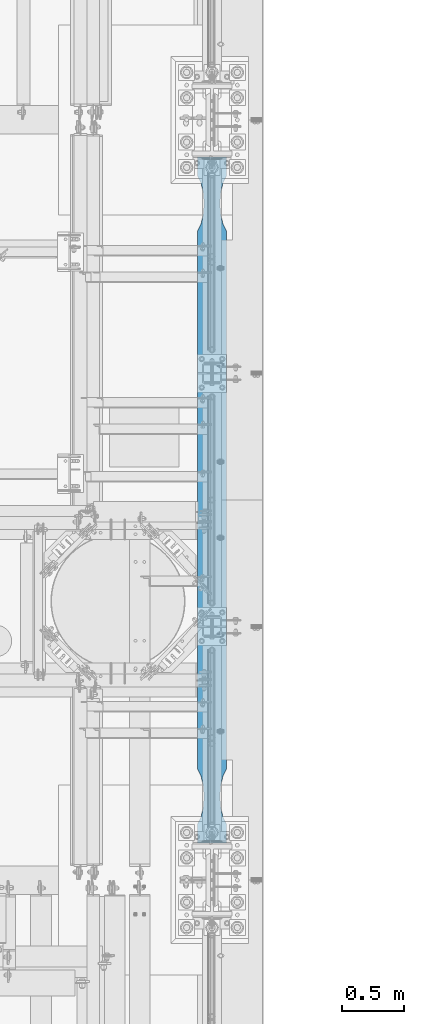
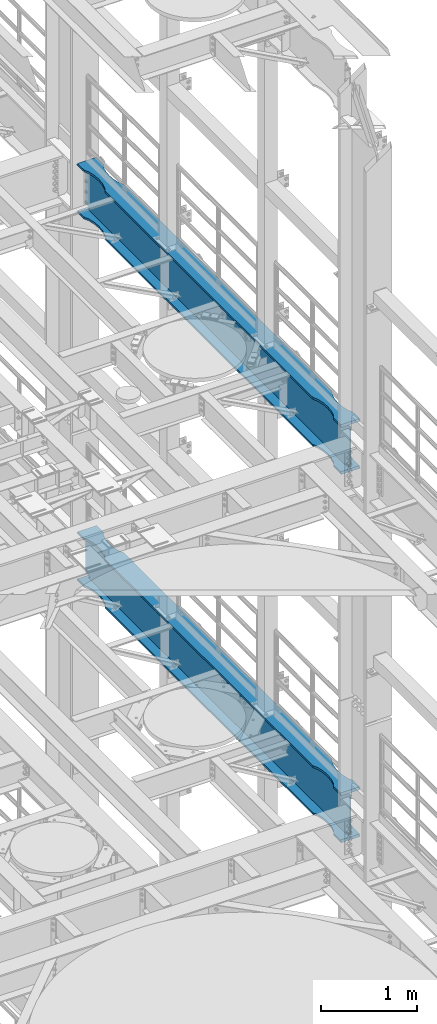
# One storey, part 1038 of 1876: 2 beams, 2 elements without a shape of their own.
"""IFC2X3 building model written with IfcOpenShell, lengths in millimetres."""

from ifc_helpers import new_model, si_unit, frame, origin_with_axes, place, context, subcontext, project, spatial, faceted_brep, material, type_object, element, aggregate, save


model = new_model("IFC2X3")

# Units and contexts
model_context = context("Model", 3, precision=1e-05, world=origin_with_axes())
body_context = subcontext(model_context, "Body", "Model", "MODEL_VIEW")
ifc_project = project(units=[si_unit("LENGTHUNIT", "METRE", prefix="MILLI"), si_unit("AREAUNIT", "SQUARE_METRE"), si_unit("VOLUMEUNIT", "CUBIC_METRE"), si_unit("MASSUNIT", "GRAM", prefix="KILO"), si_unit("TIMEUNIT", "SECOND"), si_unit("PLANEANGLEUNIT", "RADIAN"), si_unit("SOLIDANGLEUNIT", "STERADIAN"), si_unit("THERMODYNAMICTEMPERATUREUNIT", "DEGREE_CELSIUS"), si_unit("LUMINOUSINTENSITYUNIT", "LUMEN")], contexts=[model_context])

# Site, building, storey
site_placement = place(None, origin_with_axes())
site = spatial("IfcSite", under=ifc_project, at=site_placement, CompositionType="ELEMENT")
building_placement = place(site_placement, origin_with_axes())
building = spatial("IfcBuilding", under=site, at=building_placement, Name="Undefined", CompositionType="ELEMENT")
storey_placement = place(building_placement, origin_with_axes())
storey = spatial("IfcBuildingStorey", under=building, at=storey_placement, Name="Undefined", CompositionType="ELEMENT", Elevation=0.0)

# Assembly, beam
assembly_1_placement = place(storey_placement, origin_with_axes())
assembly_1 = element("IfcElementAssembly", 1, at=assembly_1_placement, inside=storey, Name="BEAM", AssemblyPlace="NOTDEFINED", PredefinedType="RIGID_FRAME")
ifc_material = material(Name="STEEL/A992")
beam_type = type_object("IfcBeamType", Name="W24X103", PredefinedType="NOTDEFINED")
beam_1_placement = place(assembly_1_placement, frame((7620.0, 1524.0, 17672.05), z_axis=(0.0, 0.0, 1.0), x_axis=(0.0, 1.0, 0.0)))
beam_1 = element("IfcBeam", 2, at=beam_1_placement, type_object=beam_type, material=ifc_material, Name="BEAM", ObjectType="W24X103", context=body_context, shape_type="Brep", body=[
    faceted_brep([(5789.6125, -7.14375000000018, -250.825000000001), (5797.55, 7.14375000000018, -250.825000000001), (5797.55, 7.14375000000018, 250.825000000001), (5789.6125, -7.14375000000018, 250.825000000001), (306.3875, -7.14375000000018, 250.825000000001), (298.45, 7.14375000000018, 250.825000000001), (298.45, 7.14375000000018, -250.825000000001), (306.3875, -7.14375000000018, -250.825000000001), (5641.97500876196, 114.299992330618, -285.75), (5641.97500876196, 114.3, -311.150000000001), (5592.87586146151, 88.8999957361821, -311.150000000001), (5592.87586146151, 88.8999957361821, -285.75), (5510.43685211057, 69.8863924058523, -311.150000000001), (5510.43685211057, 69.8863924058523, -285.75), (5426.0750039875, 63.5000040971918, -311.150000000001), (5426.0750039875, 63.5000040971918, -285.75), (5341.71315599965, 69.8863941921136, -311.150000000001), (5341.71315599965, 69.8863941921136, -285.75), (5259.2741470513, 88.8999992679901, -311.150000000001), (5259.2741470513, 88.8999992679901, -285.75), (5210.175, 114.3, -311.150000000001), (5210.175, 114.3, -285.75), (885.825008761703, 114.3, -311.150000000001), (885.825008761703, 114.299990374483, -285.75), (836.72586171043, 88.899989642473, -311.150000000001), (836.72586171043, 88.899989642473, -285.75), (754.286852762112, 69.8863845665965, -311.150000000001), (754.286852762112, 69.8863845665965, -285.75), (669.925004774302, 63.4999944716747, -311.150000000001), (669.925004774302, 63.4999944716747, -285.75), (585.563156651265, 69.8863827803352, -311.150000000001), (585.563156651265, 69.8863827803352, -285.75), (503.124147300347, 88.8999861106649, -311.150000000001), (503.124147300347, 88.8999861106649, -285.75), (454.024999999921, 114.3, -311.150000000001), (454.024999999921, 114.3, -285.75), (298.45, 114.3, -311.150000000001), (313.11459905754, 114.3, -285.75), (5641.97500876196, -114.299992330618, -285.75), (5592.87586146151, -88.8999957361821, -285.75), (5592.87586146151, -88.8999957361821, -311.150000000001), (5641.97500876196, -114.3, -311.150000000001), (5510.43685211057, -69.8863924058523, -285.75), (5510.43685211057, -69.8863924058523, -311.150000000001), (5426.0750039875, -63.5000040971918, -285.75), (5426.0750039875, -63.5000040971918, -311.150000000001), (5341.71315599965, -69.8863941921136, -285.75), (5341.71315599965, -69.8863941921136, -311.150000000001), (5259.2741470513, -88.8999992679901, -285.75), (5259.2741470513, -88.8999992679901, -311.150000000001), (5210.175, -114.3, -285.75), (5210.175, -114.3, -311.150000000001), (885.825008761703, -114.300009625517, -285.75), (885.825008761703, -114.3, -311.150000000001), (836.72586171043, -88.9000088935072, -285.75), (836.72586171043, -88.9000088935072, -311.150000000001), (754.286852762112, -69.8864038176307, -285.75), (754.286852762112, -69.8864038176307, -311.150000000001), (669.925004774302, -63.5000137227089, -285.75), (669.925004774302, -63.5000137227089, -311.150000000001), (585.563156651265, -69.8864020313695, -285.75), (585.563156651265, -69.8864020313695, -311.150000000001), (503.124147300347, -88.9000053616992, -285.75), (503.124147300347, -88.9000053616992, -311.150000000001), (454.024999999921, -114.3, -285.75), (454.024999999921, -114.3, -311.150000000001), (313.11459905754, -114.3, -285.75), (298.45, -114.3, -311.150000000001), (313.343799385621, -7.14375000000018, -285.35299987793), (313.343799385621, 7.14375000000018, -285.35299987793), (313.114599057541, 7.14375000000018, -285.75), (313.114599057541, -7.14375000000018, -285.75), (346.909996826172, -7.14375000000018, -285.35299987793), (346.909996826172, 7.14375000000018, -285.35299987793), (382.382251149282, -7.14375000000018, -269.000062630286), (382.382251149282, 7.14375000000018, -269.000062630286), (386.272459055476, -7.14375000000018, -265.703842989446), (386.272459055476, 7.14375000000018, -265.703842989446), (387.905124802588, -7.14375000000018, -260.873399528195), (387.905124802588, 7.14375000000018, -260.873399528195), (386.81238362386, -7.14375000000018, -255.89296800167), (386.81238362386, 7.14375000000018, -255.89296800167), (383.307376832887, -7.14375000000018, -252.189765486371), (383.307376832887, 7.14375000000018, -252.189765486371), (378.39451650093, -7.14375000000018, -250.825000000001), (378.39451650093, 7.14375000000018, -250.825000000001), (377.559514535493, -7.14375000000018, 250.825000000001), (377.559514535493, 7.14375000000018, 250.825000000001), (382.472374804242, -7.14375000000018, 252.189765448315), (382.472374804242, 7.14375000000018, 252.189765448315), (385.977381589376, -7.14375000000018, 255.892967871263), (385.977381589376, 7.14375000000018, 255.892967871263), (387.070122849314, -7.14375000000018, 260.873399307191), (387.070122849314, 7.14375000000018, 260.873399307191), (385.437457255921, -7.14375000000018, 265.703842745359), (385.437457255921, 7.14375000000018, 265.703842745359), (381.547249518856, -7.14375000000018, 269.000062475843), (381.547249518856, 7.14375000000018, 269.000062475843), (346.074998474121, -7.14375000000018, 285.35299987793), (346.074998474121, 7.14375000000018, 285.35299987793), (298.45, -7.14375000000018, 285.35299987793), (298.45, 7.14375000000018, 285.35299987793), (454.024999999921, 114.3, 311.150000000001), (454.024999999921, 114.3, 285.75), (298.45, 114.3, 285.75), (313.114586308271, 114.3, 311.150000000001), (503.124147300347, 88.8999861106649, 311.150000000001), (503.124147300347, 88.8999861106649, 285.75), (585.563156651265, 69.8863827803352, 311.150000000001), (585.563156651265, 69.8863827803352, 285.75), (669.925004774302, 63.4999944716747, 311.150000000001), (669.925004774302, 63.4999944716747, 285.75), (754.286852762112, 69.8863845665965, 311.150000000001), (754.286852762112, 69.8863845665965, 285.75), (836.72586171043, 88.899989642473, 311.150000000001), (836.72586171043, 88.899989642473, 285.75), (885.825008761703, 114.299990374483, 311.150000000001), (885.825008761703, 114.3, 285.75), (5210.175, 114.3, 311.150000000001), (5210.175, 114.3, 285.75), (5259.2741470513, 88.8999992679901, 311.150000000001), (5259.2741470513, 88.8999992679901, 285.75), (5341.71315599965, 69.8863941921136, 311.150000000001), (5341.71315599965, 69.8863941921136, 285.75), (5426.0750039875, 63.5000040971918, 311.150000000001), (5426.0750039875, 63.5000040971918, 285.75), (5510.43685211057, 69.8863924058523, 311.150000000001), (5510.43685211057, 69.8863924058523, 285.75), (5592.87586146151, 88.8999957361821, 311.150000000001), (5592.87586146151, 88.8999957361821, 285.75), (5641.97500876196, 114.299992330618, 311.150000000001), (5641.97500876196, 114.3, 285.75), (5782.88541369173, 114.29999927708, 311.150000000001), (5797.55, 114.3, 285.75), (298.45, 7.14375000000018, 285.75), (5797.55, 7.14375000000018, 285.75), (5797.55, -7.14375000000018, 285.35299987793), (5797.55, 7.14375000000018, 285.35299987793), (5797.55, -7.14375000000018, 285.75), (5749.92500152588, -7.14375000000018, 285.35299987793), (5749.92500152588, 7.14375000000018, 285.35299987793), (5714.45275048114, -7.14375000000018, 269.000062475843), (5714.45275048114, 7.14375000000018, 269.000062475843), (5710.56254274408, -7.14375000000018, 265.703842745359), (5710.56254274408, 7.14375000000018, 265.703842745359), (5708.92987715069, -7.14375000000018, 260.873399307191), (5708.92987715069, 7.14375000000018, 260.873399307191), (5710.02261841062, -7.14375000000018, 255.892967871263), (5710.02261841062, 7.14375000000018, 255.892967871263), (5713.52762519576, -7.14375000000018, 252.189765448315), (5713.52762519576, 7.14375000000018, 252.189765448315), (5718.44048546451, -7.14375000000018, 250.825000000001), (5718.44048546451, 7.14375000000018, 250.825000000001), (5717.60548349907, -7.14375000000018, -250.825000000001), (5717.60548349907, 7.14375000000018, -250.825000000001), (5712.69262316711, -7.14375000000018, -252.189765486371), (5712.69262316711, 7.14375000000018, -252.189765486371), (5709.18761637614, -7.14375000000018, -255.89296800167), (5709.18761637614, 7.14375000000018, -255.89296800167), (5708.09487519741, -7.14375000000018, -260.873399528195), (5708.09487519741, 7.14375000000018, -260.873399528195), (5709.72754094452, -7.14375000000018, -265.703842989446), (5709.72754094452, 7.14375000000018, -265.703842989446), (5713.61774885072, -7.14375000000018, -269.000062630286), (5713.61774885072, 7.14375000000018, -269.000062630286), (5749.09000317383, -7.14375000000018, -285.35299987793), (5749.09000317383, 7.14375000000018, -285.35299987793), (5782.65620061438, -7.14375000000018, -285.35299987793), (5782.65620061438, 7.14375000000018, -285.35299987793), (5782.88540094246, 7.14375000000018, -285.75), (5782.88540094246, 114.299999277079, -285.75), (5797.55, 114.3, -311.150000000001), (5797.55, -114.3, -311.150000000001), (5782.88540094246, -114.299999277079, -285.75), (5782.88540094246, -7.14375000000018, -285.75), (298.45, -7.14375000000018, 285.75), (313.114586308271, -114.3, 311.150000000001), (298.45, -114.3, 285.75), (454.024999999921, -114.3, 285.75), (454.024999999921, -114.3, 311.150000000001), (503.124147300347, -88.9000053616992, 285.75), (503.124147300347, -88.9000053616992, 311.150000000001), (585.563156651265, -69.8864020313695, 285.75), (585.563156651265, -69.8864020313695, 311.150000000001), (669.925004774302, -63.5000137227089, 285.75), (669.925004774302, -63.5000137227089, 311.150000000001), (754.286852762112, -69.8864038176307, 285.75), (754.286852762112, -69.8864038176307, 311.150000000001), (836.72586171043, -88.9000088935072, 285.75), (836.72586171043, -88.9000088935072, 311.150000000001), (885.825008761703, -114.300009625517, 311.150000000001), (885.825008761703, -114.3, 285.75), (5210.175, -114.3, 285.75), (5210.175, -114.3, 311.150000000001), (5259.2741470513, -88.8999992679901, 285.75), (5259.2741470513, -88.8999992679901, 311.150000000001), (5341.71315599965, -69.8863941921136, 285.75), (5341.71315599965, -69.8863941921136, 311.150000000001), (5426.0750039875, -63.5000040971918, 285.75), (5426.0750039875, -63.5000040971918, 311.150000000001), (5510.43685211057, -69.8863924058523, 285.75), (5510.43685211057, -69.8863924058523, 311.150000000001), (5592.87586146151, -88.8999957361821, 285.75), (5592.87586146151, -88.8999957361821, 311.150000000001), (5641.97500876196, -114.299992330618, 311.150000000001), (5641.97500876196, -114.3, 285.75), (5797.55, -114.3, 285.75), (5782.88541369173, -114.29999927708, 311.150000000001)], [[[0, 1, 2, 3]], [[4, 5, 6, 7]], [[8, 9, 10, 11]], [[11, 10, 12, 13]], [[13, 12, 14, 15]], [[15, 14, 16, 17]], [[17, 16, 18, 19]], [[19, 18, 20, 21]], [[21, 20, 22, 23]], [[23, 22, 24, 25]], [[25, 24, 26, 27]], [[27, 26, 28, 29]], [[29, 28, 30, 31]], [[31, 30, 32, 33]], [[33, 32, 34, 35]], [[35, 34, 36, 37]], [[38, 39, 40, 41]], [[42, 43, 40, 39]], [[44, 45, 43, 42]], [[46, 47, 45, 44]], [[48, 49, 47, 46]], [[50, 51, 49, 48]], [[51, 50, 52, 53]], [[52, 54, 55, 53]], [[56, 57, 55, 54]], [[58, 59, 57, 56]], [[60, 61, 59, 58]], [[62, 63, 61, 60]], [[64, 65, 63, 62]], [[65, 64, 66, 67]], [[68, 69, 70, 37, 36, 67, 66, 71]], [[72, 73, 69, 68]], [[74, 75, 73, 72]], [[76, 77, 75, 74]], [[78, 79, 77, 76]], [[80, 81, 79, 78]], [[82, 83, 81, 80]], [[84, 85, 83, 82]], [[85, 84, 7, 6]], [[86, 87, 5, 4]], [[88, 89, 87, 86]], [[90, 91, 89, 88]], [[92, 93, 91, 90]], [[94, 95, 93, 92]], [[96, 97, 95, 94]], [[98, 99, 97, 96]], [[99, 98, 100, 101]], [[102, 103, 104, 105]], [[106, 107, 103, 102]], [[108, 109, 107, 106]], [[110, 111, 109, 108]], [[112, 113, 111, 110]], [[114, 115, 113, 112]], [[116, 117, 115, 114]], [[118, 119, 117, 116]], [[120, 121, 119, 118]], [[122, 123, 121, 120]], [[124, 125, 123, 122]], [[126, 127, 125, 124]], [[128, 129, 127, 126]], [[130, 131, 129, 128]], [[131, 130, 132, 133]], [[134, 104, 103, 107, 109, 111, 113, 115, 117, 119, 121, 123, 125, 127, 129, 131, 133, 135]], [[136, 137, 135, 138]], [[139, 140, 137, 136]], [[141, 142, 140, 139]], [[143, 144, 142, 141]], [[145, 146, 144, 143]], [[147, 148, 146, 145]], [[149, 150, 148, 147]], [[151, 152, 150, 149]], [[152, 151, 3, 2]], [[153, 154, 1, 0]], [[155, 156, 154, 153]], [[157, 158, 156, 155]], [[159, 160, 158, 157]], [[161, 162, 160, 159]], [[163, 164, 162, 161]], [[165, 166, 164, 163]], [[166, 165, 167, 168]], [[70, 69, 73, 75, 77, 79, 81, 83, 85, 6, 5, 87, 89, 91, 93, 95, 97, 99, 101, 134, 135, 137, 140, 142, 144, 146, 148, 150, 152, 2, 1, 154, 156, 158, 160, 162, 164, 166, 168, 169]], [[8, 11, 13, 15, 17, 19, 21, 23, 25, 27, 29, 31, 33, 35, 37, 70, 169, 170]], [[9, 8, 170, 171]], [[41, 40, 43, 45, 47, 49, 51, 53, 55, 57, 59, 61, 63, 65, 67, 36, 34, 32, 30, 28, 26, 24, 22, 20, 18, 16, 14, 12, 10, 9, 171, 172]], [[38, 41, 172, 173]], [[71, 66, 64, 62, 60, 58, 56, 54, 52, 50, 48, 46, 44, 42, 39, 38, 173, 174]], [[172, 171, 170, 169, 168, 167, 174, 173]], [[151, 149, 147, 145, 143, 141, 139, 136, 138, 175, 100, 98, 96, 94, 92, 90, 88, 86, 4, 7, 84, 82, 80, 78, 76, 74, 72, 68, 71, 174, 167, 165, 163, 161, 159, 157, 155, 153, 0, 3]], [[101, 100, 175, 134]], [[176, 105, 104, 134, 175, 177]], [[178, 179, 176, 177]], [[179, 178, 180, 181]], [[181, 180, 182, 183]], [[183, 182, 184, 185]], [[185, 184, 186, 187]], [[187, 186, 188, 189]], [[190, 189, 188, 191]], [[192, 193, 190, 191]], [[193, 192, 194, 195]], [[195, 194, 196, 197]], [[197, 196, 198, 199]], [[199, 198, 200, 201]], [[201, 200, 202, 203]], [[204, 205, 206, 207]], [[130, 128, 126, 124, 122, 120, 118, 116, 114, 112, 110, 108, 106, 102, 105, 176, 179, 181, 183, 185, 187, 189, 190, 193, 195, 197, 199, 201, 203, 204, 207, 132]], [[206, 138, 135, 133, 132, 207]], [[205, 202, 200, 198, 196, 194, 192, 191, 188, 186, 184, 182, 180, 178, 177, 175, 138, 206]], [[204, 203, 202, 205]]]),
])
aggregate(assembly_1, [beam_1])

assembly_2_placement = place(storey_placement, origin_with_axes())
assembly_2 = element("IfcElementAssembly", 3, at=assembly_2_placement, inside=storey, Name="BEAM", AssemblyPlace="NOTDEFINED", PredefinedType="RIGID_FRAME")
beam_2_placement = place(assembly_2_placement, frame((7620.0, 1524.0, 12998.45), z_axis=(0.0, 0.0, 1.0), x_axis=(0.0, 1.0, 0.0)))
beam_2 = element("IfcBeam", 4, at=beam_2_placement, type_object=beam_type, material=ifc_material, Name="BEAM", ObjectType="W24X103", context=body_context, shape_type="Brep", body=[
    faceted_brep([(5789.6125, -7.14375000000018, -250.825000000001), (5797.55, 7.14375000000018, -250.825000000001), (5797.55, 7.14375000000018, 250.825000000001), (5789.6125, -7.14375000000018, 250.825000000001), (306.3875, -7.14375000000018, 250.825000000001), (298.45, 7.14375000000018, 250.825000000001), (298.45, 7.14375000000018, -250.825000000001), (306.3875, -7.14375000000018, -250.825000000001), (5797.55, -114.3, 285.75), (5797.55, -7.14375000000018, 285.75), (5797.55, 7.14375000000018, 285.75), (5797.55, 114.3, 285.75), (5782.88541369173, 114.29999927708, 311.150000000001), (5782.88541369173, -114.29999927708, 311.150000000001), (5641.97500876196, 114.299992330618, 311.150000000001), (5641.97500876196, 114.3, 285.75), (5592.87586146151, 88.8999957361821, 285.75), (5592.87586146151, 88.8999957361821, 311.150000000001), (5510.43685211057, 69.8863924058523, 285.75), (5510.43685211057, 69.8863924058523, 311.150000000001), (5426.0750039875, 63.5000040971918, 285.75), (5426.0750039875, 63.5000040971918, 311.150000000001), (5341.71315599965, 69.8863941921136, 285.75), (5341.71315599965, 69.8863941921136, 311.150000000001), (5259.2741470513, 88.8999992679901, 285.75), (5259.2741470513, 88.8999992679901, 311.150000000001), (5210.175, 114.3, 285.75), (5210.175, 114.3, 311.150000000001), (885.825008761703, 114.3, 285.75), (885.825008761703, 114.299990374483, 311.150000000001), (836.72586171043, 88.899989642473, 285.75), (836.72586171043, 88.899989642473, 311.150000000001), (754.286852762112, 69.8863845665965, 285.75), (754.286852762112, 69.8863845665965, 311.150000000001), (669.925004774302, 63.4999944716747, 285.75), (669.925004774302, 63.4999944716747, 311.150000000001), (585.563156651265, 69.8863827803352, 285.75), (585.563156651265, 69.8863827803352, 311.150000000001), (503.124147300347, 88.8999861106649, 285.75), (503.124147300347, 88.8999861106649, 311.150000000001), (454.024999999921, 114.3, 285.75), (454.024999999921, 114.3, 311.150000000001), (298.45, 114.3, 285.75), (313.114586308271, 114.3, 311.150000000001), (5641.97500876196, 114.299992330618, -285.75), (5641.97500876196, 114.3, -311.150000000001), (5592.87586146151, 88.8999957361821, -311.150000000001), (5592.87586146151, 88.8999957361821, -285.75), (5510.43685211057, 69.8863924058523, -311.150000000001), (5510.43685211057, 69.8863924058523, -285.75), (5426.0750039875, 63.5000040971918, -311.150000000001), (5426.0750039875, 63.5000040971918, -285.75), (5341.71315599965, 69.8863941921136, -311.150000000001), (5341.71315599965, 69.8863941921136, -285.75), (5259.2741470513, 88.8999992679901, -311.150000000001), (5259.2741470513, 88.8999992679901, -285.75), (5210.175, 114.3, -311.150000000001), (5210.175, 114.3, -285.75), (885.825008761703, 114.3, -311.150000000001), (885.825008761703, 114.299990374483, -285.75), (836.72586171043, 88.899989642473, -311.150000000001), (836.72586171043, 88.899989642473, -285.75), (754.286852762112, 69.8863845665965, -311.150000000001), (754.286852762112, 69.8863845665965, -285.75), (669.925004774302, 63.4999944716747, -311.150000000001), (669.925004774302, 63.4999944716747, -285.75), (585.563156651265, 69.8863827803352, -311.150000000001), (585.563156651265, 69.8863827803352, -285.75), (503.124147300347, 88.8999861106649, -311.150000000001), (503.124147300347, 88.8999861106649, -285.75), (454.024999999921, 114.3, -311.150000000001), (454.024999999921, 114.3, -285.75), (298.45, 114.3, -311.150000000001), (313.11459905754, 114.3, -285.75), (5641.97500876196, -114.299992330618, -285.75), (5592.87586146151, -88.8999957361821, -285.75), (5592.87586146151, -88.8999957361821, -311.150000000001), (5641.97500876196, -114.3, -311.150000000001), (5510.43685211057, -69.8863924058523, -285.75), (5510.43685211057, -69.8863924058523, -311.150000000001), (5426.0750039875, -63.5000040971918, -285.75), (5426.0750039875, -63.5000040971918, -311.150000000001), (5341.71315599965, -69.8863941921136, -285.75), (5341.71315599965, -69.8863941921136, -311.150000000001), (5259.2741470513, -88.8999992679901, -285.75), (5259.2741470513, -88.8999992679901, -311.150000000001), (5210.175, -114.3, -285.75), (5210.175, -114.3, -311.150000000001), (885.825008761703, -114.300009625517, -285.75), (885.825008761703, -114.3, -311.150000000001), (836.72586171043, -88.9000088935072, -285.75), (836.72586171043, -88.9000088935072, -311.150000000001), (754.286852762112, -69.8864038176307, -285.75), (754.286852762112, -69.8864038176307, -311.150000000001), (669.925004774302, -63.5000137227089, -285.75), (669.925004774302, -63.5000137227089, -311.150000000001), (585.563156651265, -69.8864020313695, -285.75), (585.563156651265, -69.8864020313695, -311.150000000001), (503.124147300347, -88.9000053616992, -285.75), (503.124147300347, -88.9000053616992, -311.150000000001), (454.024999999921, -114.3, -285.75), (454.024999999921, -114.3, -311.150000000001), (313.11459905754, -114.3, -285.75), (298.45, -114.3, -311.150000000001), (313.343799385621, -7.14375000000018, -285.35299987793), (313.343799385621, 7.14375000000018, -285.35299987793), (313.114599057541, 7.14375000000018, -285.75), (313.114599057541, -7.14375000000018, -285.75), (346.909996826172, -7.14375000000018, -285.35299987793), (346.909996826172, 7.14375000000018, -285.35299987793), (382.382251149282, -7.14375000000018, -269.000062630286), (382.382251149282, 7.14375000000018, -269.000062630286), (386.272459055476, -7.14375000000018, -265.703842989446), (386.272459055476, 7.14375000000018, -265.703842989446), (387.905124802588, -7.14375000000018, -260.873399528195), (387.905124802588, 7.14375000000018, -260.873399528195), (386.81238362386, -7.14375000000018, -255.89296800167), (386.81238362386, 7.14375000000018, -255.89296800167), (383.307376832887, -7.14375000000018, -252.189765486371), (383.307376832887, 7.14375000000018, -252.189765486371), (378.39451650093, -7.14375000000018, -250.825000000001), (378.39451650093, 7.14375000000018, -250.825000000001), (377.559514535493, -7.14375000000018, 250.825000000001), (377.559514535493, 7.14375000000018, 250.825000000001), (382.472374804242, -7.14375000000018, 252.189765448315), (382.472374804242, 7.14375000000018, 252.189765448315), (385.977381589376, -7.14375000000018, 255.892967871263), (385.977381589376, 7.14375000000018, 255.892967871263), (387.070122849314, -7.14375000000018, 260.873399307191), (387.070122849314, 7.14375000000018, 260.873399307191), (385.437457255921, -7.14375000000018, 265.703842745359), (385.437457255921, 7.14375000000018, 265.703842745359), (381.547249518856, -7.14375000000018, 269.000062475843), (381.547249518856, 7.14375000000018, 269.000062475843), (346.074998474121, -7.14375000000018, 285.35299987793), (346.074998474121, 7.14375000000018, 285.35299987793), (298.45, -7.14375000000018, 285.35299987793), (298.45, 7.14375000000018, 285.35299987793), (298.45, -7.14375000000018, 285.75), (298.45, 7.14375000000018, 285.75), (313.114586308271, -114.3, 311.150000000001), (298.45, -114.3, 285.75), (454.024999999921, -114.3, 285.75), (454.024999999921, -114.3, 311.150000000001), (503.124147300347, -88.9000053616992, 285.75), (503.124147300347, -88.9000053616992, 311.150000000001), (585.563156651265, -69.8864020313695, 285.75), (585.563156651265, -69.8864020313695, 311.150000000001), (669.925004774302, -63.5000137227089, 285.75), (669.925004774302, -63.5000137227089, 311.150000000001), (754.286852762112, -69.8864038176307, 285.75), (754.286852762112, -69.8864038176307, 311.150000000001), (836.72586171043, -88.9000088935072, 285.75), (836.72586171043, -88.9000088935072, 311.150000000001), (885.825008761703, -114.300009625517, 311.150000000001), (885.825008761703, -114.3, 285.75), (5210.175, -114.3, 285.75), (5210.175, -114.3, 311.150000000001), (5259.2741470513, -88.8999992679901, 285.75), (5259.2741470513, -88.8999992679901, 311.150000000001), (5341.71315599965, -69.8863941921136, 285.75), (5341.71315599965, -69.8863941921136, 311.150000000001), (5426.0750039875, -63.5000040971918, 285.75), (5426.0750039875, -63.5000040971918, 311.150000000001), (5510.43685211057, -69.8863924058523, 285.75), (5510.43685211057, -69.8863924058523, 311.150000000001), (5592.87586146151, -88.8999957361821, 285.75), (5592.87586146151, -88.8999957361821, 311.150000000001), (5641.97500876196, -114.299992330618, 311.150000000001), (5641.97500876196, -114.3, 285.75), (5797.55, -7.14375000000018, 285.35299987793), (5797.55, 7.14375000000018, 285.35299987793), (5749.92500152588, -7.14375000000018, 285.35299987793), (5749.92500152588, 7.14375000000018, 285.35299987793), (5714.45275048114, -7.14375000000018, 269.000062475843), (5714.45275048114, 7.14375000000018, 269.000062475843), (5710.56254274408, -7.14375000000018, 265.703842745359), (5710.56254274408, 7.14375000000018, 265.703842745359), (5708.92987715069, -7.14375000000018, 260.873399307191), (5708.92987715069, 7.14375000000018, 260.873399307191), (5710.02261841062, -7.14375000000018, 255.892967871263), (5710.02261841062, 7.14375000000018, 255.892967871263), (5713.52762519576, -7.14375000000018, 252.189765448315), (5713.52762519576, 7.14375000000018, 252.189765448315), (5718.44048546451, -7.14375000000018, 250.825000000001), (5718.44048546451, 7.14375000000018, 250.825000000001), (5717.60548349907, -7.14375000000018, -250.825000000001), (5717.60548349907, 7.14375000000018, -250.825000000001), (5712.69262316711, -7.14375000000018, -252.189765486371), (5712.69262316711, 7.14375000000018, -252.189765486371), (5709.18761637614, -7.14375000000018, -255.89296800167), (5709.18761637614, 7.14375000000018, -255.89296800167), (5708.09487519741, -7.14375000000018, -260.873399528195), (5708.09487519741, 7.14375000000018, -260.873399528195), (5709.72754094452, -7.14375000000018, -265.703842989446), (5709.72754094452, 7.14375000000018, -265.703842989446), (5713.61774885072, -7.14375000000018, -269.000062630286), (5713.61774885072, 7.14375000000018, -269.000062630286), (5749.09000317383, -7.14375000000018, -285.35299987793), (5749.09000317383, 7.14375000000018, -285.35299987793), (5782.65620061438, -7.14375000000018, -285.35299987793), (5782.65620061438, 7.14375000000018, -285.35299987793), (5782.88540094246, 7.14375000000018, -285.75), (5782.88540094246, 114.299999277079, -285.75), (5797.55, 114.3, -311.150000000001), (5797.55, -114.3, -311.150000000001), (5782.88540094246, -114.299999277079, -285.75), (5782.88540094246, -7.14375000000018, -285.75)], [[[0, 1, 2, 3]], [[4, 5, 6, 7]], [[8, 9, 10, 11, 12, 13]], [[14, 15, 16, 17]], [[17, 16, 18, 19]], [[19, 18, 20, 21]], [[21, 20, 22, 23]], [[23, 22, 24, 25]], [[25, 24, 26, 27]], [[27, 26, 28, 29]], [[29, 28, 30, 31]], [[31, 30, 32, 33]], [[33, 32, 34, 35]], [[35, 34, 36, 37]], [[37, 36, 38, 39]], [[39, 38, 40, 41]], [[41, 40, 42, 43]], [[44, 45, 46, 47]], [[47, 46, 48, 49]], [[49, 48, 50, 51]], [[51, 50, 52, 53]], [[53, 52, 54, 55]], [[55, 54, 56, 57]], [[57, 56, 58, 59]], [[59, 58, 60, 61]], [[61, 60, 62, 63]], [[63, 62, 64, 65]], [[65, 64, 66, 67]], [[67, 66, 68, 69]], [[69, 68, 70, 71]], [[71, 70, 72, 73]], [[74, 75, 76, 77]], [[78, 79, 76, 75]], [[80, 81, 79, 78]], [[82, 83, 81, 80]], [[84, 85, 83, 82]], [[86, 87, 85, 84]], [[87, 86, 88, 89]], [[88, 90, 91, 89]], [[92, 93, 91, 90]], [[94, 95, 93, 92]], [[96, 97, 95, 94]], [[98, 99, 97, 96]], [[100, 101, 99, 98]], [[101, 100, 102, 103]], [[104, 105, 106, 73, 72, 103, 102, 107]], [[108, 109, 105, 104]], [[110, 111, 109, 108]], [[112, 113, 111, 110]], [[114, 115, 113, 112]], [[116, 117, 115, 114]], [[118, 119, 117, 116]], [[120, 121, 119, 118]], [[121, 120, 7, 6]], [[122, 123, 5, 4]], [[124, 125, 123, 122]], [[126, 127, 125, 124]], [[128, 129, 127, 126]], [[130, 131, 129, 128]], [[132, 133, 131, 130]], [[134, 135, 133, 132]], [[135, 134, 136, 137]], [[137, 136, 138, 139]], [[140, 43, 42, 139, 138, 141]], [[142, 143, 140, 141]], [[143, 142, 144, 145]], [[145, 144, 146, 147]], [[147, 146, 148, 149]], [[149, 148, 150, 151]], [[151, 150, 152, 153]], [[154, 153, 152, 155]], [[156, 157, 154, 155]], [[157, 156, 158, 159]], [[159, 158, 160, 161]], [[161, 160, 162, 163]], [[163, 162, 164, 165]], [[165, 164, 166, 167]], [[168, 167, 166, 169]], [[168, 169, 8, 13]], [[14, 17, 19, 21, 23, 25, 27, 29, 31, 33, 35, 37, 39, 41, 43, 140, 143, 145, 147, 149, 151, 153, 154, 157, 159, 161, 163, 165, 167, 168, 13, 12]], [[15, 14, 12, 11]], [[139, 42, 40, 38, 36, 34, 32, 30, 28, 26, 24, 22, 20, 18, 16, 15, 11, 10]], [[170, 171, 10, 9]], [[172, 173, 171, 170]], [[174, 175, 173, 172]], [[176, 177, 175, 174]], [[178, 179, 177, 176]], [[180, 181, 179, 178]], [[182, 183, 181, 180]], [[184, 185, 183, 182]], [[185, 184, 3, 2]], [[186, 187, 1, 0]], [[188, 189, 187, 186]], [[190, 191, 189, 188]], [[192, 193, 191, 190]], [[194, 195, 193, 192]], [[196, 197, 195, 194]], [[198, 199, 197, 196]], [[199, 198, 200, 201]], [[106, 105, 109, 111, 113, 115, 117, 119, 121, 6, 5, 123, 125, 127, 129, 131, 133, 135, 137, 139, 10, 171, 173, 175, 177, 179, 181, 183, 185, 2, 1, 187, 189, 191, 193, 195, 197, 199, 201, 202]], [[44, 47, 49, 51, 53, 55, 57, 59, 61, 63, 65, 67, 69, 71, 73, 106, 202, 203]], [[45, 44, 203, 204]], [[77, 76, 79, 81, 83, 85, 87, 89, 91, 93, 95, 97, 99, 101, 103, 72, 70, 68, 66, 64, 62, 60, 58, 56, 54, 52, 50, 48, 46, 45, 204, 205]], [[74, 77, 205, 206]], [[107, 102, 100, 98, 96, 94, 92, 90, 88, 86, 84, 82, 80, 78, 75, 74, 206, 207]], [[205, 204, 203, 202, 201, 200, 207, 206]], [[184, 182, 180, 178, 176, 174, 172, 170, 9, 138, 136, 134, 132, 130, 128, 126, 124, 122, 4, 7, 120, 118, 116, 114, 112, 110, 108, 104, 107, 207, 200, 198, 196, 194, 192, 190, 188, 186, 0, 3]], [[169, 166, 164, 162, 160, 158, 156, 155, 152, 150, 148, 146, 144, 142, 141, 138, 9, 8]]]),
])
aggregate(assembly_2, [beam_2])

save(model, "model.ifc")
